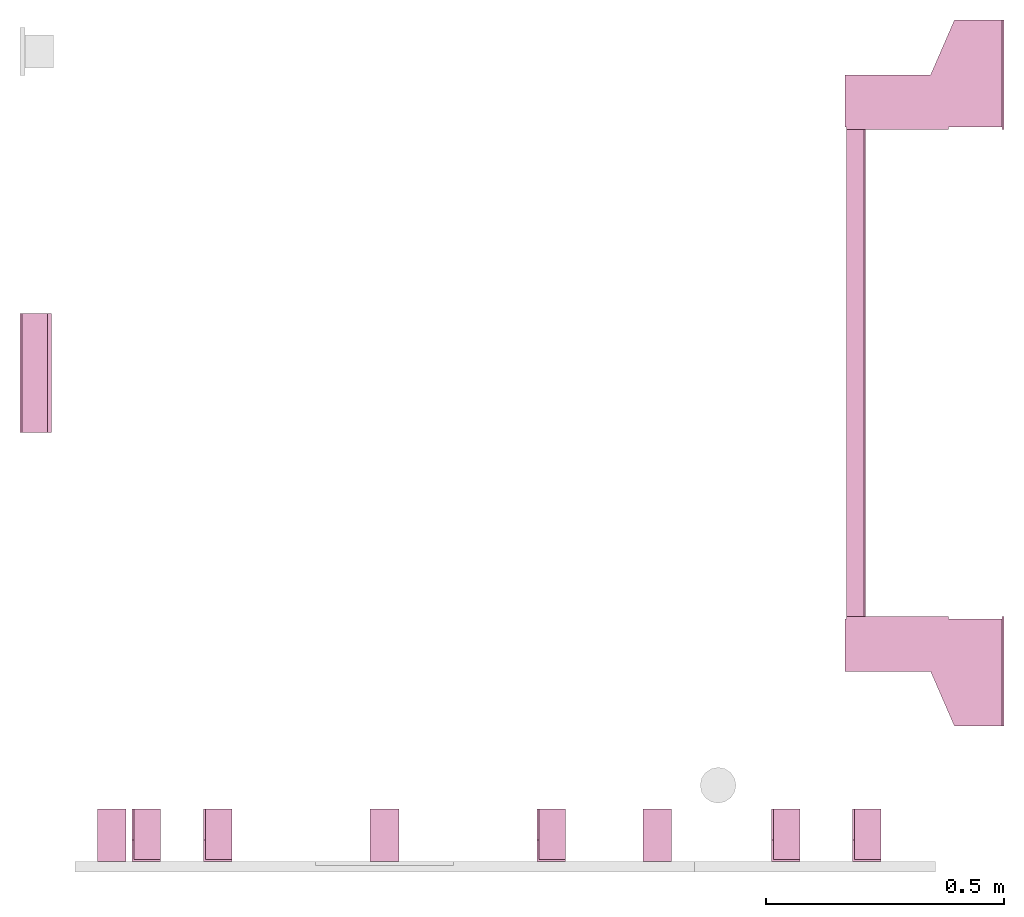
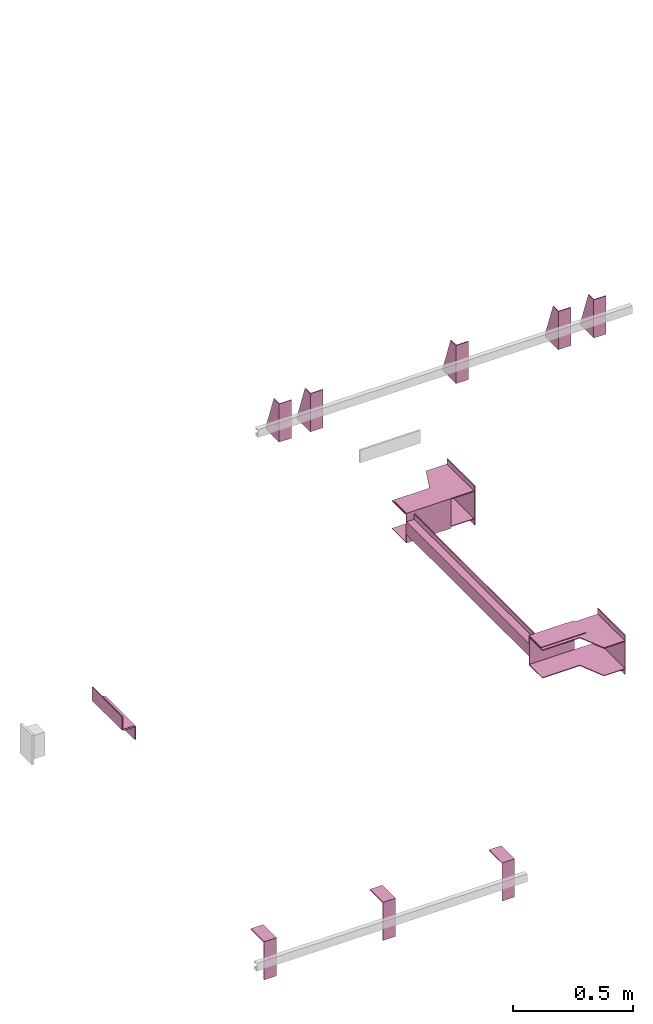
# One storey, part 4 of 4: 10 transport elements.
"""IFC4 building model written with IfcOpenShell, lengths in millimetres."""

from ifc_helpers import new_model, entity, si_unit, converted_unit, frame, origin_with_axes, place, context, subcontext, project, spatial, faceted_brep, element, save


model = new_model("IFC4")

# Units and contexts
context_of_model = context(None, 3, precision=0.01, world=origin_with_axes())
sub_context_1 = subcontext(context_of_model, None, None, "MODEL_VIEW")
sub_context_2 = subcontext(context_of_model, None, None, "MODEL_VIEW")
sub_context_3 = subcontext(context_of_model, None, None, "MODEL_VIEW")
sub_context_4 = subcontext(context_of_model, None, None, "MODEL_VIEW")
sub_context_5 = subcontext(context_of_model, None, None, "MODEL_VIEW")
sub_context_6 = subcontext(context_of_model, None, None, "MODEL_VIEW")
sub_context_7 = subcontext(context_of_model, None, None, "MODEL_VIEW")
sub_context_8 = subcontext(context_of_model, None, None, "MODEL_VIEW")
sub_context_9 = subcontext(context_of_model, None, None, "MODEL_VIEW")
sub_context_10 = subcontext(context_of_model, None, None, "MODEL_VIEW")
ifc_project = project(units=[converted_unit("PLANEANGLEUNIT", "degree", entity("IfcPlaneAngleMeasure", 0.017453292519943), si_unit("PLANEANGLEUNIT", "RADIAN"), dimensions=[0, 0, 0, 0, 0, 0, 0]), si_unit("LENGTHUNIT", "METRE", prefix="MILLI"), si_unit("MASSUNIT", "GRAM", prefix="KILO"), converted_unit("TIMEUNIT", "year", entity("IfcTimeMeasure", 31557600.0), si_unit("TIMEUNIT", "SECOND"), dimensions=[0, 0, 1, 0, 0, 0, 0]), si_unit("THERMODYNAMICTEMPERATUREUNIT", "DEGREE_CELSIUS"), si_unit("AREAUNIT", "SQUARE_METRE"), si_unit("FORCEUNIT", "NEWTON"), si_unit("VOLUMEUNIT", "CUBIC_METRE"), si_unit("PRESSUREUNIT", "PASCAL"), si_unit("SOLIDANGLEUNIT", "STERADIAN")], contexts=[context_of_model])

# Site, building, storey
site = spatial("IfcSite", under=ifc_project)
building = spatial("IfcBuilding", under=site, Name="Document")
placement = place(None, origin_with_axes())
storey_placement = place(placement, frame((0.0, 0.0, -23290.0), z_axis=(0.0, 0.0, 1.0), x_axis=(1.0, 0.0, 0.0)))
storey = spatial("IfcBuildingStorey", under=building, at=storey_placement, Name="P10", Elevation=-23290.0)

# Transport elements
transport_element_1_placement = place(storey_placement, frame((2065.0, 1025.0, 590.0), z_axis=(0.0, 0.0, 1.0), x_axis=(0.0, 1.0, 0.0)))
element("IfcTransportElement", 1, at=transport_element_1_placement, inside=storey, PredefinedType="ELEVATOR", context=sub_context_1, shape_type="Brep", body=[
    faceted_brep([(-611.0, 331.0, -72.5), (-514.0, 331.0, -72.5), (-514.0, 331.0, 72.5), (-611.0, 331.0, 72.5), (-611.0, 331.0, 75.5), (-511.0, 331.0, 75.5), (-511.0, 331.0, -75.5), (-611.0, 331.0, -75.5), (-511.0, 116.0, -75.5), (-511.0, 116.0, 75.5), (-611.0, 116.0, 75.5), (-611.0, 116.0, 72.5), (-514.0, 116.0, 72.5), (-514.0, 116.0, -72.5), (-611.0, 116.0, -72.5), (-611.0, 116.0, -75.5)], [[[0, 1, 2, 3, 4, 5, 6, 7]], [[8, 9, 10, 11, 12, 13, 14, 15]], [[15, 14, 0, 7]], [[13, 12, 2, 1]], [[5, 9, 8, 6]], [[11, 10, 4, 3]], [[6, 8, 15, 7]], [[14, 13, 1, 0]], [[2, 12, 11, 3]], [[10, 9, 5, 4]]]),
    faceted_brep([(-511.0, 291.0, 59.5), (-511.0, 294.0, 59.5), (-511.0, 294.0, 32.5), (-511.0, 291.0, 32.5), (511.0, 291.0, 59.5), (511.0, 291.0, 32.5), (511.0, 294.0, 32.5), (511.0, 294.0, 59.5)], [[[0, 1, 2, 3]], [[4, 5, 6, 7]], [[0, 3, 5, 4]], [[3, 2, 6, 5]], [[2, 1, 7, 6]], [[1, 0, 4, 7]]]),
    faceted_brep([(-511.0, 291.0, -32.5), (-511.0, 294.0, -32.5), (-511.0, 294.0, -59.5), (-511.0, 291.0, -59.5), (511.0, 291.0, -32.5), (511.0, 291.0, -59.5), (511.0, 294.0, -59.5), (511.0, 294.0, -32.5)], [[[0, 1, 2, 3]], [[4, 5, 6, 7]], [[0, 3, 5, 4]], [[3, 2, 6, 5]], [[2, 1, 7, 6]], [[1, 0, 4, 7]]]),
    faceted_brep([(511.0, 331.0, 75.5), (611.0, 331.0, 75.5), (611.0, 331.0, 72.5), (514.0, 331.0, 72.5), (514.0, 331.0, -72.5), (611.0, 331.0, -72.5), (611.0, 331.0, -75.5), (511.0, 331.0, -75.5), (511.0, 116.0, -75.5), (611.0, 116.0, -75.5), (611.0, 116.0, -72.5), (514.0, 116.0, -72.5), (514.0, 116.0, 72.5), (611.0, 116.0, 72.5), (611.0, 116.0, 75.5), (511.0, 116.0, 75.5)], [[[0, 1, 2, 3, 4, 5, 6, 7]], [[8, 9, 10, 11, 12, 13, 14, 15]], [[8, 15, 0, 7]], [[3, 12, 11, 4]], [[5, 10, 9, 6]], [[1, 14, 13, 2]], [[6, 9, 8, 7]], [[11, 10, 5, 4]], [[15, 14, 1, 0]], [[2, 13, 12, 3]]]),
    faceted_brep([(-511.0, 331.0, 32.5), (511.0, 331.0, 32.5), (511.0, 331.0, -32.5), (-511.0, 331.0, -32.5), (511.0, 328.0, -29.5), (511.0, 328.0, 29.5), (-511.0, 328.0, 29.5), (-511.0, 328.0, -29.5), (511.0, 291.0, -32.5), (511.0, 291.0, -29.5), (-511.0, 291.0, -29.5), (-511.0, 291.0, -32.5), (511.0, 291.0, 29.5), (511.0, 291.0, 32.5), (-511.0, 291.0, 32.5), (-511.0, 291.0, 29.5)], [[[0, 1, 2, 3]], [[4, 5, 6, 7]], [[8, 9, 10, 11]], [[12, 13, 14, 15]], [[11, 10, 7, 6, 15, 14, 0, 3]], [[2, 1, 13, 12, 5, 4, 9, 8]], [[2, 8, 11, 3]], [[10, 9, 4, 7]], [[14, 13, 1, 0]], [[5, 12, 15, 6]]]),
    faceted_brep([(-626.0, 334.0, -68.5), (-516.0, 334.0, -68.5), (-516.0, 334.0, -72.5), (-626.0, 334.0, -72.5), (-516.0, 4.0, -72.5), (-516.0, 4.0, -68.5), (-741.0, 4.0, -68.5), (-741.0, 4.0, -72.5), (-741.0, 104.0, -68.5), (-626.0, 154.0, -68.5), (-626.0, 154.0, -72.5), (-741.0, 104.0, -72.5)], [[[0, 1, 2, 3]], [[4, 5, 6, 7]], [[8, 9, 10, 11]], [[10, 9, 0, 3]], [[1, 5, 4, 2]], [[7, 6, 8, 11]], [[2, 4, 7, 11, 10, 3]], [[9, 8, 6, 5, 1, 0]]]),
    faceted_brep([(516.0, 334.0, -68.5), (626.0, 334.0, -68.5), (626.0, 334.0, -72.5), (516.0, 334.0, -72.5), (741.0, 4.0, -72.5), (741.0, 4.0, -68.5), (516.0, 4.0, -68.5), (516.0, 4.0, -72.5), (626.0, 154.0, -68.5), (741.0, 104.0, -68.5), (741.0, 104.0, -72.5), (626.0, 154.0, -72.5)], [[[0, 1, 2, 3]], [[4, 5, 6, 7]], [[8, 9, 10, 11]], [[7, 6, 0, 3]], [[1, 8, 11, 2]], [[9, 5, 4, 10]], [[2, 11, 10, 4, 7, 3]], [[6, 5, 9, 8, 1, 0]]]),
    faceted_brep([(516.0, 334.0, 72.5), (626.0, 334.0, 72.5), (626.0, 334.0, 68.5), (516.0, 334.0, 68.5), (741.0, 4.0, 68.5), (741.0, 4.0, 72.5), (516.0, 4.0, 72.5), (516.0, 4.0, 68.5), (626.0, 154.0, 72.5), (741.0, 104.0, 72.5), (741.0, 104.0, 68.5), (626.0, 154.0, 68.5)], [[[0, 1, 2, 3]], [[4, 5, 6, 7]], [[8, 9, 10, 11]], [[7, 6, 0, 3]], [[1, 8, 11, 2]], [[9, 5, 4, 10]], [[2, 11, 10, 4, 7, 3]], [[6, 5, 9, 8, 1, 0]]]),
    faceted_brep([(-626.0, 334.0, 72.5), (-516.0, 334.0, 72.5), (-516.0, 334.0, 68.5), (-626.0, 334.0, 68.5), (-516.0, 4.0, 68.5), (-516.0, 4.0, 72.5), (-741.0, 4.0, 72.5), (-741.0, 4.0, 68.5), (-741.0, 104.0, 72.5), (-626.0, 154.0, 72.5), (-626.0, 154.0, 68.5), (-741.0, 104.0, 68.5)], [[[0, 1, 2, 3]], [[4, 5, 6, 7]], [[8, 9, 10, 11]], [[10, 9, 0, 3]], [[1, 5, 4, 2]], [[7, 6, 8, 11]], [[2, 4, 7, 11, 10, 3]], [[9, 8, 6, 5, 1, 0]]]),
    faceted_brep([(741.0, 0.0, -100.0), (741.0, 0.0, 100.0), (511.0, 0.0, 100.0), (511.0, 0.0, -100.0), (741.0, 4.0, -100.0), (511.0, 4.0, -100.0), (511.0, 4.0, 100.0), (741.0, 4.0, 100.0)], [[[0, 1, 2, 3]], [[4, 5, 6, 7]], [[0, 3, 5, 4]], [[3, 2, 6, 5]], [[2, 1, 7, 6]], [[1, 0, 4, 7]]]),
    faceted_brep([(-511.0, 0.0, -100.0), (-511.0, 0.0, 100.0), (-741.0, 0.0, 100.0), (-741.0, 0.0, -100.0), (-511.0, 4.0, -100.0), (-741.0, 4.0, -100.0), (-741.0, 4.0, 100.0), (-511.0, 4.0, 100.0)], [[[0, 1, 2, 3]], [[4, 5, 6, 7]], [[0, 3, 5, 4]], [[3, 2, 6, 5]], [[2, 1, 7, 6]], [[1, 0, 4, 7]]]),
])
transport_element_2_placement = place(storey_placement, frame((265.0, 0.0, 2580.0), z_axis=(0.0, 0.0, 1.0), x_axis=(1.0, 0.0, 0.0)))
element("IfcTransportElement", 2, at=transport_element_2_placement, inside=storey, PredefinedType="ELEVATOR", context=sub_context_2, shape_type="Brep", body=[
    faceted_brep([(-30.0, 4.0, -93.0), (-30.0, 4.0, 97.0), (-30.0, 45.0, 97.0), (-30.0, 110.0, -82.0), (-30.0, 110.0, -93.0), (-26.0, 4.0, -93.0), (-26.0, 110.0, -93.0), (-26.0, 110.0, -82.0), (-26.0, 45.0, 97.0), (-26.0, 4.0, 97.0)], [[[0, 1, 2, 3, 4]], [[5, 6, 7, 8, 9]], [[5, 0, 4, 6]], [[6, 4, 3, 7]], [[7, 3, 2, 8]], [[8, 2, 1, 9]], [[9, 1, 0, 5]]]),
    faceted_brep([(-30.0, 0.0, -97.0), (-30.0, 0.0, 97.0), (-30.0, 4.0, 97.0), (-30.0, 4.0, -93.0), (-30.0, 110.0, -93.0), (-30.0, 110.0, -97.0), (30.0, 110.0, -97.0), (30.0, 110.0, -93.0), (30.0, 4.0, -93.0), (30.0, 4.0, 97.0), (30.0, 0.0, 97.0), (30.0, 0.0, -97.0)], [[[0, 1, 2, 3, 4, 5]], [[6, 7, 8, 9, 10, 11]], [[11, 10, 1, 0]], [[2, 9, 8, 3]], [[4, 7, 6, 5]], [[5, 6, 11, 0]], [[8, 7, 4, 3]], [[10, 9, 2, 1]]]),
])
transport_element_3_placement = place(storey_placement, frame((415.0, 0.0, 2580.0), z_axis=(0.0, 0.0, 1.0), x_axis=(1.0, 0.0, 0.0)))
element("IfcTransportElement", 3, at=transport_element_3_placement, inside=storey, PredefinedType="ELEVATOR", context=sub_context_3, shape_type="Brep", body=[
    faceted_brep([(-30.0, 0.0, -97.0), (-30.0, 0.0, 97.0), (-30.0, 4.0, 97.0), (-30.0, 4.0, -93.0), (-30.0, 110.0, -93.0), (-30.0, 110.0, -97.0), (30.0, 110.0, -97.0), (30.0, 110.0, -93.0), (30.0, 4.0, -93.0), (30.0, 4.0, 97.0), (30.0, 0.0, 97.0), (30.0, 0.0, -97.0)], [[[0, 1, 2, 3, 4, 5]], [[6, 7, 8, 9, 10, 11]], [[11, 10, 1, 0]], [[2, 9, 8, 3]], [[4, 7, 6, 5]], [[5, 6, 11, 0]], [[8, 7, 4, 3]], [[10, 9, 2, 1]]]),
    faceted_brep([(-30.0, 4.0, -93.0), (-30.0, 4.0, 97.0), (-30.0, 45.0, 97.0), (-30.0, 110.0, -82.0), (-30.0, 110.0, -93.0), (-26.0, 4.0, -93.0), (-26.0, 110.0, -93.0), (-26.0, 110.0, -82.0), (-26.0, 45.0, 97.0), (-26.0, 4.0, 97.0)], [[[0, 1, 2, 3, 4]], [[5, 6, 7, 8, 9]], [[5, 0, 4, 6]], [[6, 4, 3, 7]], [[7, 3, 2, 8]], [[8, 2, 1, 9]], [[9, 1, 0, 5]]]),
])
transport_element_4_placement = place(storey_placement, frame((1115.0, 0.0, 2580.0), z_axis=(0.0, 0.0, 1.0), x_axis=(1.0, 0.0, 0.0)))
element("IfcTransportElement", 4, at=transport_element_4_placement, inside=storey, PredefinedType="ELEVATOR", context=sub_context_4, shape_type="Brep", body=[
    faceted_brep([(-30.0, 0.0, -97.0), (-30.0, 0.0, 97.0), (-30.0, 4.0, 97.0), (-30.0, 4.0, -93.0), (-30.0, 110.0, -93.0), (-30.0, 110.0, -97.0), (30.0, 110.0, -97.0), (30.0, 110.0, -93.0), (30.0, 4.0, -93.0), (30.0, 4.0, 97.0), (30.0, 0.0, 97.0), (30.0, 0.0, -97.0)], [[[0, 1, 2, 3, 4, 5]], [[6, 7, 8, 9, 10, 11]], [[11, 10, 1, 0]], [[2, 9, 8, 3]], [[4, 7, 6, 5]], [[5, 6, 11, 0]], [[8, 7, 4, 3]], [[10, 9, 2, 1]]]),
    faceted_brep([(-30.0, 4.0, -93.0), (-30.0, 4.0, 97.0), (-30.0, 45.0, 97.0), (-30.0, 110.0, -82.0), (-30.0, 110.0, -93.0), (-26.0, 4.0, -93.0), (-26.0, 110.0, -93.0), (-26.0, 110.0, -82.0), (-26.0, 45.0, 97.0), (-26.0, 4.0, 97.0)], [[[0, 1, 2, 3, 4]], [[5, 6, 7, 8, 9]], [[5, 0, 4, 6]], [[6, 4, 3, 7]], [[7, 3, 2, 8]], [[8, 2, 1, 9]], [[9, 1, 0, 5]]]),
])
transport_element_5_placement = place(storey_placement, frame((1607.0, 0.0, 2580.0), z_axis=(0.0, 0.0, 1.0), x_axis=(1.0, 0.0, 0.0)))
element("IfcTransportElement", 5, at=transport_element_5_placement, inside=storey, PredefinedType="ELEVATOR", context=sub_context_5, shape_type="Brep", body=[
    faceted_brep([(-30.0, 4.0, -93.0), (-30.0, 4.0, 97.0), (-30.0, 45.0, 97.0), (-30.0, 110.0, -82.0), (-30.0, 110.0, -93.0), (-26.0, 4.0, -93.0), (-26.0, 110.0, -93.0), (-26.0, 110.0, -82.0), (-26.0, 45.0, 97.0), (-26.0, 4.0, 97.0)], [[[0, 1, 2, 3, 4]], [[5, 6, 7, 8, 9]], [[5, 0, 4, 6]], [[6, 4, 3, 7]], [[7, 3, 2, 8]], [[8, 2, 1, 9]], [[9, 1, 0, 5]]]),
    faceted_brep([(-30.0, 0.0, -97.0), (-30.0, 0.0, 97.0), (-30.0, 4.0, 97.0), (-30.0, 4.0, -93.0), (-30.0, 110.0, -93.0), (-30.0, 110.0, -97.0), (30.0, 110.0, -97.0), (30.0, 110.0, -93.0), (30.0, 4.0, -93.0), (30.0, 4.0, 97.0), (30.0, 0.0, 97.0), (30.0, 0.0, -97.0)], [[[0, 1, 2, 3, 4, 5]], [[6, 7, 8, 9, 10, 11]], [[11, 10, 1, 0]], [[2, 9, 8, 3]], [[4, 7, 6, 5]], [[5, 6, 11, 0]], [[8, 7, 4, 3]], [[10, 9, 2, 1]]]),
])
transport_element_6_placement = place(storey_placement, frame((1777.0, 0.0, 2580.0), z_axis=(0.0, 0.0, 1.0), x_axis=(1.0, 0.0, 0.0)))
element("IfcTransportElement", 6, at=transport_element_6_placement, inside=storey, PredefinedType="ELEVATOR", context=sub_context_6, shape_type="Brep", body=[
    faceted_brep([(-30.0, 0.0, -97.0), (-30.0, 0.0, 97.0), (-30.0, 4.0, 97.0), (-30.0, 4.0, -93.0), (-30.0, 110.0, -93.0), (-30.0, 110.0, -97.0), (30.0, 110.0, -97.0), (30.0, 110.0, -93.0), (30.0, 4.0, -93.0), (30.0, 4.0, 97.0), (30.0, 0.0, 97.0), (30.0, 0.0, -97.0)], [[[0, 1, 2, 3, 4, 5]], [[6, 7, 8, 9, 10, 11]], [[11, 10, 1, 0]], [[2, 9, 8, 3]], [[4, 7, 6, 5]], [[5, 6, 11, 0]], [[8, 7, 4, 3]], [[10, 9, 2, 1]]]),
    faceted_brep([(-30.0, 4.0, -93.0), (-30.0, 4.0, 97.0), (-30.0, 45.0, 97.0), (-30.0, 110.0, -82.0), (-30.0, 110.0, -93.0), (-26.0, 4.0, -93.0), (-26.0, 110.0, -93.0), (-26.0, 110.0, -82.0), (-26.0, 45.0, 97.0), (-26.0, 4.0, 97.0)], [[[0, 1, 2, 3, 4]], [[5, 6, 7, 8, 9]], [[5, 0, 4, 6]], [[6, 4, 3, 7]], [[7, 3, 2, 8]], [[8, 2, 1, 9]], [[9, 1, 0, 5]]]),
])
transport_element_7_placement = place(storey_placement, frame((1337.5, 0.0, -30.0), z_axis=(0.0, 0.0, -1.0), x_axis=(-1.0, 0.0, 0.0)))
element("IfcTransportElement", 7, at=transport_element_7_placement, inside=storey, PredefinedType="ELEVATOR", context=sub_context_7, shape_type="Brep", body=[
    faceted_brep([(30.0, 0.0, 0.0), (30.0, 110.0, 0.0), (30.0, 110.0, 4.0), (30.0, 4.0, 4.0), (30.0, 4.0, 194.0), (30.0, 0.0, 194.0), (-30.0, 4.0, 194.0), (-30.0, 4.0, 4.0), (-30.0, 110.0, 4.0), (-30.0, 110.0, 0.0), (-30.0, 0.0, 0.0), (-30.0, 0.0, 194.0)], [[[0, 1, 2, 3, 4, 5]], [[6, 7, 8, 9, 10, 11]], [[11, 10, 0, 5]], [[3, 7, 6, 4]], [[1, 9, 8, 2]], [[4, 6, 11, 5]], [[10, 9, 1, 0]], [[2, 8, 7, 3]]]),
    faceted_brep([(-30.0, 4.0, 4.0), (-30.0, 4.0, 194.0), (-30.0, 45.0, 194.0), (-30.0, 110.0, 15.0), (-30.0, 110.0, 4.0), (-26.0, 4.0, 4.0), (-26.0, 110.0, 4.0), (-26.0, 110.0, 15.0), (-26.0, 45.0, 194.0), (-26.0, 4.0, 194.0)], [[[0, 1, 2, 3, 4]], [[5, 6, 7, 8, 9]], [[5, 0, 4, 6]], [[6, 4, 3, 7]], [[7, 3, 2, 8]], [[8, 2, 1, 9]], [[9, 1, 0, 5]]]),
])
transport_element_8_placement = place(storey_placement, frame((765.0, 0.0, -30.0), z_axis=(0.0, 0.0, -1.0), x_axis=(-1.0, 0.0, 0.0)))
element("IfcTransportElement", 8, at=transport_element_8_placement, inside=storey, PredefinedType="ELEVATOR", context=sub_context_8, shape_type="Brep", body=[
    faceted_brep([(30.0, 0.0, 0.0), (30.0, 110.0, 0.0), (30.0, 110.0, 4.0), (30.0, 4.0, 4.0), (30.0, 4.0, 194.0), (30.0, 0.0, 194.0), (-30.0, 4.0, 194.0), (-30.0, 4.0, 4.0), (-30.0, 110.0, 4.0), (-30.0, 110.0, 0.0), (-30.0, 0.0, 0.0), (-30.0, 0.0, 194.0)], [[[0, 1, 2, 3, 4, 5]], [[6, 7, 8, 9, 10, 11]], [[11, 10, 0, 5]], [[3, 7, 6, 4]], [[1, 9, 8, 2]], [[4, 6, 11, 5]], [[10, 9, 1, 0]], [[2, 8, 7, 3]]]),
    faceted_brep([(-30.0, 4.0, 4.0), (-30.0, 4.0, 194.0), (-30.0, 45.0, 194.0), (-30.0, 110.0, 15.0), (-30.0, 110.0, 4.0), (-26.0, 4.0, 4.0), (-26.0, 110.0, 4.0), (-26.0, 110.0, 15.0), (-26.0, 45.0, 194.0), (-26.0, 4.0, 194.0)], [[[0, 1, 2, 3, 4]], [[5, 6, 7, 8, 9]], [[5, 0, 4, 6]], [[6, 4, 3, 7]], [[7, 3, 2, 8]], [[8, 2, 1, 9]], [[9, 1, 0, 5]]]),
])
transport_element_9_placement = place(storey_placement, frame((192.5, 0.0, -30.0), z_axis=(0.0, 0.0, -1.0), x_axis=(-1.0, 0.0, 0.0)))
element("IfcTransportElement", 9, at=transport_element_9_placement, inside=storey, PredefinedType="ELEVATOR", context=sub_context_9, shape_type="Brep", body=[
    faceted_brep([(30.0, 0.0, 0.0), (30.0, 110.0, 0.0), (30.0, 110.0, 4.0), (30.0, 4.0, 4.0), (30.0, 4.0, 194.0), (30.0, 0.0, 194.0), (-30.0, 4.0, 194.0), (-30.0, 4.0, 4.0), (-30.0, 110.0, 4.0), (-30.0, 110.0, 0.0), (-30.0, 0.0, 0.0), (-30.0, 0.0, 194.0)], [[[0, 1, 2, 3, 4, 5]], [[6, 7, 8, 9, 10, 11]], [[11, 10, 0, 5]], [[3, 7, 6, 4]], [[1, 9, 8, 2]], [[4, 6, 11, 5]], [[10, 9, 1, 0]], [[2, 8, 7, 3]]]),
    faceted_brep([(-30.0, 4.0, 4.0), (-30.0, 4.0, 194.0), (-30.0, 45.0, 194.0), (-30.0, 110.0, 15.0), (-30.0, 110.0, 4.0), (-26.0, 4.0, 4.0), (-26.0, 110.0, 4.0), (-26.0, 110.0, 15.0), (-26.0, 45.0, 194.0), (-26.0, 4.0, 194.0)], [[[0, 1, 2, 3, 4]], [[5, 6, 7, 8, 9]], [[5, 0, 4, 6]], [[6, 4, 3, 7]], [[7, 3, 2, 8]], [[8, 2, 1, 9]], [[9, 1, 0, 5]]]),
])
transport_element_10_placement = place(storey_placement, frame((0.0, 1025.0, 590.0), z_axis=(0.0, 0.0, 1.0), x_axis=(0.0, -1.0, 0.0)))
element("IfcTransportElement", 10, at=transport_element_10_placement, inside=storey, PredefinedType="ELEVATOR", context=sub_context_10, shape_type="Brep", body=[
    faceted_brep([(125.0, 8.0, -35.0), (-125.0, 8.0, -35.0), (-125.0, 8.0, -39.0), (125.0, 8.0, -39.0), (125.0, 62.0, -39.0), (-125.0, 62.0, -39.0), (-125.0, 62.0, -105.0), (125.0, 62.0, -105.0), (-125.0, 66.0, -105.0), (-125.0, 66.0, -35.0), (125.0, 66.0, -35.0), (125.0, 66.0, -105.0)], [[[0, 1, 2, 3]], [[4, 5, 6, 7]], [[8, 9, 10, 11]], [[4, 7, 11, 10, 0, 3]], [[1, 9, 8, 6, 5, 2]], [[2, 5, 4, 3]], [[10, 9, 1, 0]], [[6, 8, 11, 7]]]),
    faceted_brep([(125.0, 0.0, 35.0), (-125.0, 0.0, 35.0), (-125.0, 0.0, -35.0), (125.0, 0.0, -35.0), (-125.0, 4.0, -31.0), (-125.0, 4.0, 35.0), (125.0, 4.0, 35.0), (125.0, 4.0, -31.0), (-125.0, 58.0, -35.0), (-125.0, 58.0, -31.0), (125.0, 58.0, -31.0), (125.0, 58.0, -35.0)], [[[0, 1, 2, 3]], [[4, 5, 6, 7]], [[8, 9, 10, 11]], [[11, 10, 7, 6, 0, 3]], [[2, 1, 5, 4, 9, 8]], [[2, 8, 11, 3]], [[10, 9, 4, 7]], [[6, 5, 1, 0]]]),
])

save(model, "model.ifc")
